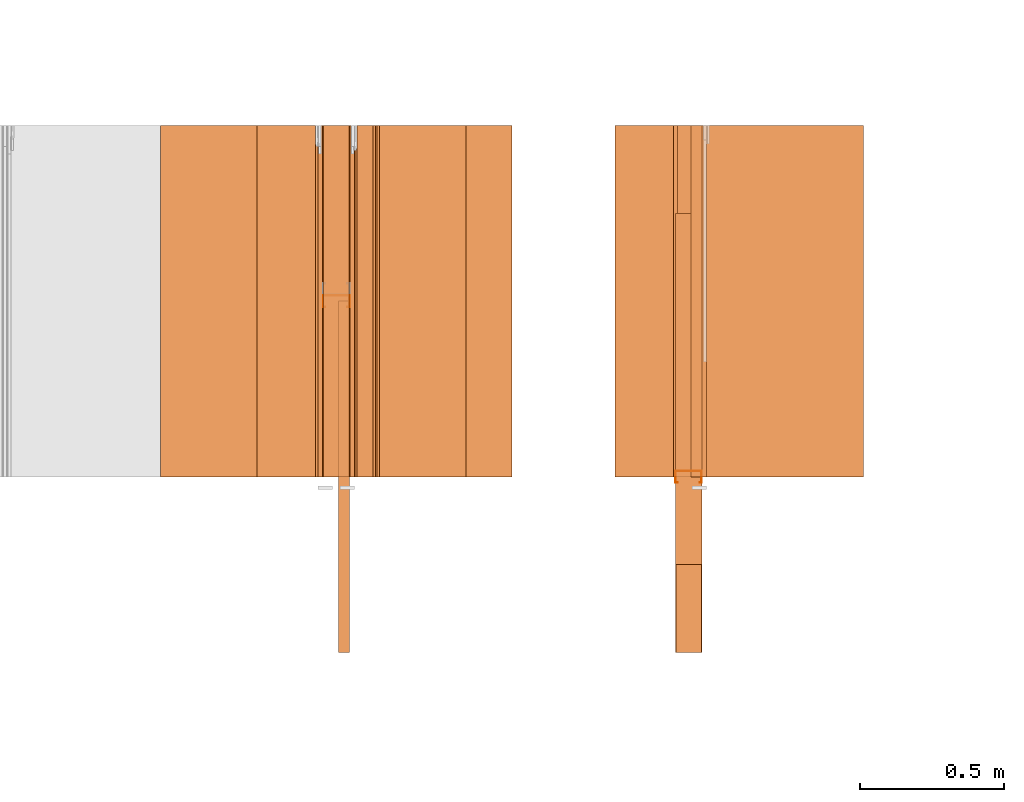
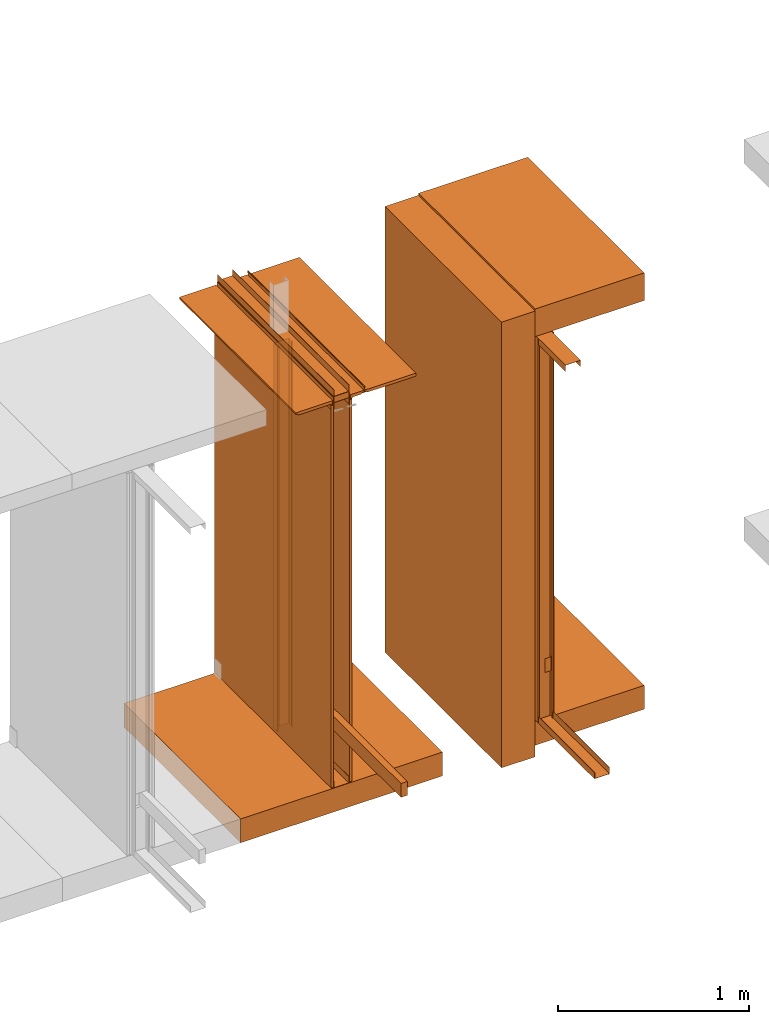
# One storey, part 38 of 64: 26 proxies.
"""IFC4 building model written with IfcOpenShell, lengths in feet."""

from ifc_helpers import new_model, entity, si_unit, converted_unit, frame, origin_with_axes, origin_2d_with_axis, place, context, subcontext, project, spatial, polyline, line, indexed_curve, outline, extrude, material, element, save


model = new_model("IFC4")

# Units and contexts
model_context_1 = context("Model", 3, precision=1e-05, world=origin_with_axes())
plan_context = context("Plan", 2, precision=1e-05, world=origin_2d_with_axis())
model_context_2 = context("Model", 3, precision=1e-05, world=origin_with_axes())
context_of_model_1 = context(None, 3, precision=1e-05, world=origin_with_axes())
context_of_model_2 = context(None, 3, precision=1e-05, world=origin_with_axes())
body_context = subcontext(model_context_2, "Body", "Model", "MODEL_VIEW")
ifc_project = project(units=[converted_unit("PLANEANGLEUNIT", "degree", entity("IfcReal", 0.0174532925199433), si_unit("PLANEANGLEUNIT", "RADIAN"), dimensions=[0, 0, 0, 0, 0, 0, 0]), converted_unit("AREAUNIT", "square foot", entity("IfcReal", 0.09290304), si_unit("AREAUNIT", "SQUARE_METRE"), dimensions=[2, 0, 0, 0, 0, 0, 0]), converted_unit("LENGTHUNIT", "foot", entity("IfcReal", 0.3048), si_unit("LENGTHUNIT", "METRE"), dimensions=[1, 0, 0, 0, 0, 0, 0]), converted_unit("VOLUMEUNIT", "cubic foot", entity("IfcReal", 0.0283168467116885), si_unit("VOLUMEUNIT", "CUBIC_METRE"), dimensions=[3, 0, 0, 0, 0, 0, 0])], contexts=[model_context_1, plan_context, context_of_model_1, context_of_model_2])

# Site, building, storey
site_placement = place(None, origin_with_axes())
site = spatial("IfcSite", under=ifc_project, at=site_placement)
building_placement = place(site_placement, origin_with_axes())
building = spatial("IfcBuilding", under=site, at=building_placement, Name="Building")
storey_placement = place(building_placement, origin_with_axes())
storey = spatial("IfcBuildingStorey", under=building, at=storey_placement, Name="Storey")

# Proxies
proxy_1_placement = place(storey_placement, frame((1406.35412821932, 5.99999987860051, -0.741135700559366), z_axis=(4.37113882867379e-08, -0.999999999999999, -8.51092183247426e-15), x_axis=(1.94707183709394e-07, 0.0, 0.999999999999981)))
element("IfcBuildingElementProxy", 1, at=proxy_1_placement, inside=storey, Name="Generic Models 502:Generic Models 1", PredefinedType="COMPLEX", context=body_context, shape_type="SweptSolid", body=[
    extrude(outline(polyline([(-0.333333353749097, -4.66965471352805), (0.333333353749097, -4.66965471352805), (0.333333353749097, 4.66965471352805), (-0.333333353749097, 4.66965471352805), (-0.333333353749097, -4.66965471352805)])), frame((4.66965471352805, -0.333332449315101, -4.3084304278221e-07), z_axis=(-3.30130176396781e-14, 1.19209268234499e-07, -1.0), x_axis=(-1.94707169498542e-07, 1.0, 1.19209268234499e-07)), (-4.20686507851542e-09, -1.62255897606656e-08, -1.0), 4.00000000752362),
])
ifc_material_1 = material()
proxy_2_placement = place(storey_placement, frame((1407.04167483673, 4.00000004943587, 0.0), z_axis=(4.37113882867379e-08, -0.999999999999999, -8.51092183247426e-15), x_axis=(1.94707183709394e-07, 0.0, 0.999999999999981)))
element("IfcBuildingElementProxy", 2, at=proxy_2_placement, inside=storey, material=ifc_material_1, Name="Generic Models 551:Generic Models 1", PredefinedType="COMPLEX", context=body_context, shape_type="SweptSolid", body=[
    extrude(outline(polyline([(-0.0664062512026528, -0.151041638487437), (0.0690104100080769, -0.151041638487437), (0.0690104161191174, 0.151041662931599), (-0.0664062450916122, 0.151041662931599), (-0.0664062450916122, 0.145833333098669), (0.0638020801751476, 0.145833333098669), (0.0638020801751476, -0.14583334532075), (-0.0664062512026528, -0.14583334532075), (-0.0664062512026528, -0.151041638487437)])), frame((0.0690104405632795, -0.151041650709518, -1.80055693306445e-08), z_axis=(9.13299180748707e-14, 1.19209062177106e-07, -1.0), x_axis=(-1.0, -1.80510738800876e-07, 0.0)), (7.05140945633786e-10, -1.49934752113889e-11, -1.0), 4.00000000752362),
])
ifc_material_2 = material(Category="steel")
proxy_3_placement = place(storey_placement, frame((1403.03123654343, 5.99999987860051, 7.94263493044796), z_axis=(4.37113882867379e-08, -0.999999999999999, -8.51092183247426e-15), x_axis=(1.94707183709394e-07, 0.0, 0.999999999999981)))
element("IfcBuildingElementProxy", 3, at=proxy_3_placement, inside=storey, material=ifc_material_2, Name="Generic Models 559:Generic Models 1", PredefinedType="COMPLEX", context=body_context, shape_type="SweptSolid", body=[
    extrude(outline(polyline([(-0.0690104161191174, -0.151041626265356), (0.0664062450916122, -0.151041626265356), (0.0664062450916122, -0.145833333098669), (-0.0638020862861881, -0.145833333098669), (-0.0638020801751476, 0.14583334532075), (0.0664062512026528, 0.14583334532075), (0.0664062512026528, 0.15104167515368), (-0.0690104100080769, 0.15104167515368), (-0.0690104161191174, -0.151041626265356)])), frame((0.0664062756468148, -0.151041662931599, -1.800557078763e-08), z_axis=(-2.09778510751671e-13, 1.192093463942e-07, -1.0), x_axis=(-1.0, -1.80510738800876e-07, 0.0)), (7.05141722789904e-10, 1.02818017988504e-10, -1.0), 4.00000000752362),
])
ifc_material_3 = material(Category="steel")
proxy_4_placement = place(storey_placement, frame((1407.04167483673, 5.00000015957149, 7.92708296788333), z_axis=(4.37113882867379e-08, -0.999999999999999, -8.51092183247426e-15), x_axis=(1.94707183709394e-07, 0.0, 0.999999999999981)))
element("IfcBuildingElementProxy", 4, at=proxy_4_placement, inside=storey, material=ifc_material_3, Name="Generic Models 564:Generic Models 1", PredefinedType="COMPLEX", context=body_context, shape_type="SweptSolid", body=[
    extrude(outline(polyline([(-0.0690104161191174, -0.151041626265356), (0.0664062450916122, -0.151041626265356), (0.0664062450916122, -0.145833333098669), (-0.0638020862861881, -0.145833333098669), (-0.0638020801751476, 0.14583334532075), (0.0664062512026528, 0.14583334532075), (0.0664062512026528, 0.15104167515368), (-0.0690104100080769, 0.15104167515368), (-0.0690104161191174, -0.151041626265356)])), frame((0.0664062756468148, -0.151041662931599, -1.800557078763e-08), z_axis=(-2.09778510751671e-13, 1.192093463942e-07, -1.0), x_axis=(-1.0, -1.80510738800876e-07, 0.0)), (7.05141722789904e-10, 1.02818017988504e-10, -1.0), 4.00000000752362),
])
ifc_material_4 = material(Category="sand")
proxy_5_placement = place(storey_placement, frame((1407.34374679605, 5.99999987860051, 0.0208333330815585), z_axis=(4.37113882867379e-08, -0.999999999999999, -8.51092183247426e-15), x_axis=(1.94707183709394e-07, 0.0, 0.999999999999981)))
element("IfcBuildingElementProxy", 5, at=proxy_5_placement, inside=storey, material=ifc_material_4, Name="Generic Models 600:Generic Models 1", PredefinedType="COMPLEX", context=body_context, shape_type="SweptSolid", body=[
    extrude(outline(polyline([(-4.00000004943587, -0.0260416674977682), (4.00000004943587, -0.0260416674977682), (4.00000004943587, 0.0260416674977682), (-4.00000004943587, 0.0260416674977682), (-4.00000004943587, -0.0260416674977682)])), frame((4.00000004943587, -0.0260408883401024, -3.94211021364806e-07), z_axis=(-2.90393285860922e-14, 1.19209140336807e-07, -1.0), x_axis=(1.0, 1.94707183709397e-07, -5.82794243094743e-15)), (-1.26761612317949e-09, -1.26070057171468e-10, -1.0), 4.00000000752362),
])
ifc_material_5 = material(Name="2X WOOD TOP PLATE", Category="wood1")
proxy_6_placement = place(storey_placement, frame((1407.21879293287, 5.99999987860051, 0.955116717521287), z_axis=(4.37113882867379e-08, -0.999999999999999, -8.51092183247426e-15), x_axis=(1.94707183709394e-07, 0.0, 0.999999999999981)))
element("IfcBuildingElementProxy", 6, at=proxy_6_placement, inside=storey, material=ifc_material_5, Name="Generic Models 602:Generic Models 1", PredefinedType="COMPLEX", context=body_context, shape_type="SweptSolid", body=[
    extrude(outline(polyline([(-0.145833320876588, -0.0625000007724355), (0.14583334532075, -0.0625000007724355), (0.14583334532075, 0.062499994661395), (-0.145833320876588, 0.0625000007724355), (-0.145833320876588, -0.0625000007724355)])), frame((0.145833333098669, -0.0624999702172329, -3.98557174431872e-07), z_axis=(-2.66321880049375e-14, 1.19209289550781e-07, -1.0), x_axis=(1.0, 1.94707197920252e-07, 0.0)), (1.31984683598985e-11, -5.84090220634437e-10, -1.0), 4.00000000752362),
])
ifc_material_6 = material(Category="InsulationBatt")
proxy_7_placement = place(storey_placement, frame((1407.06770689156, 5.99999987860051, 0.0226435821694065), z_axis=(4.37113882867379e-08, -0.999999999999999, -8.51092183247426e-15), x_axis=(1.94707183709394e-07, 0.0, 0.999999999999981)))
element("IfcBuildingElementProxy", 7, at=proxy_7_placement, inside=storey, material=ifc_material_6, Name="Generic Models 604:Generic Models 1", PredefinedType="COMPLEX", context=body_context, shape_type="SweptSolid", body=[
    extrude(outline(polyline([(-2.54716440605053, -0.16276041422225), (5.48488003375336, -0.16276041422225), (5.48487964264677, 0.0872395888674916), (-1.32302462741772, 0.0872395827564511), (-1.32302462741772, -0.0117187696237733), (-1.61469129361506, -0.0117187650404929), (-1.61469129361506, 0.0872396010895727), (-2.54716440605053, 0.0872395888674916), (-2.54716440605053, -0.16276041422225)])), frame((2.54716440605053, -0.162759913116928, -4.10509165301612e-07), z_axis=(-2.67290834919057e-14, 1.19209289550781e-07, -1.0), x_axis=(1.0, 1.94707183709397e-07, -5.8046913765453e-15)), (-7.92265986149232e-09, -1.33251243372712e-09, -1.0), 4.00000000752362),
])
proxy_8_placement = place(storey_placement, frame((1403.03123654343, 5.99999987860051, 8.2030516909802), z_axis=(4.37113882867379e-08, -0.999999999999999, -8.51092183247426e-15), x_axis=(1.94707183709394e-07, 0.0, 0.999999999999981)))
element("IfcBuildingElementProxy", 8, at=proxy_8_placement, inside=storey, material=ifc_material_3, Name="Generic Models 609:Generic Models 1", PredefinedType="COMPLEX", context=body_context, shape_type="SweptSolid", body=[
    extrude(outline(polyline([(-0.0690104161191174, -0.151041662931599), (0.0664062450916122, -0.151041662931599), (0.0664062450916122, -0.145833333098669), (-0.0638020801751476, -0.145833333098669), (-0.0638020801751476, 0.14583334532075), (0.0664062512026528, 0.14583334532075), (0.0664062450916122, 0.151041638487437), (-0.0690104161191174, 0.151041638487437), (-0.0690104161191174, -0.151041662931599)])), frame((0.06901044667432, -0.151041650709518, -1.80055693306445e-08), z_axis=(1.39309882531656e-13, 1.19209154547661e-07, -1.0), x_axis=(1.0, 1.94707169498542e-07, -8.51092183247427e-15)), (2.86545592809162e-10, 3.3153459977342e-09, -1.0), 4.00000000752362),
])
proxy_9_placement = place(storey_placement, frame((1403.03123654343, 5.99999987860051, 0.0), z_axis=(4.37113882867379e-08, -0.999999999999999, -8.51092183247426e-15), x_axis=(1.94707183709394e-07, 0.0, 0.999999999999981)))
element("IfcBuildingElementProxy", 9, at=proxy_9_placement, inside=storey, material=ifc_material_1, Name="Generic Models 403:Generic Models 1", PredefinedType="COMPLEX", context=body_context, shape_type="SweptSolid", body=[
    extrude(outline(polyline([(-0.151041638487437, -0.069010422230158), (0.151041662931599, -0.069010422230158), (0.151041662931599, 0.0664062389805717), (0.145833333098669, 0.0664062389805717), (0.145833333098669, -0.0638020862861881), (-0.14583334532075, -0.0638020862861881), (-0.14583334532075, 0.0664062450916122), (-0.151041638487437, 0.0664062389805717), (-0.151041638487437, -0.069010422230158)])), frame((0.0690104527853605, -0.151041650709518, -1.80055693306445e-08), z_axis=(2.93181657336911e-13, 1.19208870330567e-07, -1.0), x_axis=(-1.94707169498542e-07, 0.999999940395355, 1.19209147442234e-07)), (-2.59826077320113e-10, 2.86868306886845e-10, -1.0), 4.00000000752362),
])
ifc_material_7 = material(Name="UNDERSIDE OF FLOOR ASSEMBLY", Category="sand")
proxy_10_placement = place(storey_placement, frame((1407.02084919286, 5.99999987860051, 8.06249971464863), z_axis=(4.37113882867379e-08, -0.999999999999999, -8.51092183247426e-15), x_axis=(1.94707183709394e-07, 0.0, 0.999999999999981)))
element("IfcBuildingElementProxy", 10, at=proxy_10_placement, inside=storey, material=ifc_material_7, Name="Generic Models 420:Generic Models 1", PredefinedType="COMPLEX", context=body_context, shape_type="SweptSolid", body=[
    extrude(outline(polyline([(-0.288976855048044, -1.0807292042129), (0.288976903936369, -1.0807292042129), (0.288976928380531, 1.08072910643625), (-0.288976855048044, 1.0807292042129), (-0.288976855048044, -1.0807292042129)])), frame((0.288977075045503, -1.08072910643625, -5.19939553645375e-07), z_axis=(-4.59178491941676e-14, 1.19209282445354e-07, -1.0), x_axis=(1.0, 1.94707183709397e-07, 0.0)), (2.39291231274308e-09, -7.36614191865215e-09, -1.0), 4.00000000752362),
])
ifc_material_8 = material(Name="STRUCTURAL FLOOR", Category="concrete")
proxy_11_placement = place(storey_placement, frame((1407.02084919286, 5.99999987860051, -0.500000006179484), z_axis=(4.37113882867379e-08, -0.999999999999999, -8.51092183247426e-15), x_axis=(1.94707183709394e-07, 0.0, 0.999999999999981)))
element("IfcBuildingElementProxy", 11, at=proxy_11_placement, inside=storey, material=ifc_material_8, Name="Generic Models 453:Generic Models 1", PredefinedType="COMPLEX", context=body_context, shape_type="SweptSolid", body=[
    extrude(outline(polyline([(-0.250000003089742, -1.0807292042129), (0.250000003089742, -1.0807292042129), (0.250000027533904, 1.08072930198955), (-0.250000003089742, 1.0807292042129), (-0.250000003089742, -1.0807292042129)])), frame((0.250000223087201, -1.0807292042129, -5.19939553645375e-07), z_axis=(0.0, 1.19209289550781e-07, -1.0), x_axis=(1.0, 1.94707183709397e-07, 0.0)), (2.39290653958335e-09, 1.5180740220444e-08, -1.0), 4.00000000752362),
])
ifc_material_9 = material(Category="wood1")
proxy_12_placement = place(storey_placement, frame((1403.03123654343, 5.99999987860051, 8.07805167721325), z_axis=(4.37113882867379e-08, -0.999999999999999, -8.51092183247426e-15), x_axis=(1.94707183709394e-07, 0.0, 0.999999999999981)))
element("IfcBuildingElementProxy", 12, at=proxy_12_placement, inside=storey, material=ifc_material_9, Name="Generic Models 578:Generic Models 1", PredefinedType="COMPLEX", context=body_context, shape_type="SweptSolid", body=[
    extrude(outline(polyline([(-0.0625000007724355, -0.151041638487437), (0.0625000007724355, -0.151041638487437), (0.0625000007724355, 0.151041662931599), (-0.0625000007724355, 0.151041662931599), (-0.0625000007724355, -0.151041638487437)])), frame((0.0625000313276381, -0.151041650709518, -1.80055678736589e-08), z_axis=(-1.58239036023716e-14, 1.19209289550781e-07, -1.0), x_axis=(-1.0, -1.9555329799914e-07, 0.0)), (-2.54603865768033e-10, 4.3999508897441e-11, -1.0), 4.00000000752362),
])
ifc_material_10 = material()
proxy_13_placement = place(storey_placement, frame((1403.03123654343, 3.93229167605322, 0.00520833327038962), z_axis=(0.0, 0.0, 1.0), x_axis=(1.0, 0.0, 0.0)))
element("IfcBuildingElementProxy", 13, at=proxy_13_placement, inside=storey, material=ifc_material_10, Name="Generic Models 581:Generic Models 65", PredefinedType="COMPLEX", context=body_context, shape_type="SweptSolid", body=[
    extrude(outline(polyline([(-0.0842013872983887, 0.145833333098669), (0.040798611190962, 0.145833333098669), (0.040798611190962, 0.12499998932279), (0.0460069440794116, 0.12499998932279), (0.0460069440794116, 0.151041662931599), (-0.0894097171313181, 0.151041662931599), (-0.0894097171313181, -0.151041638487437), (0.0460069440794116, -0.151041638487437), (0.0460069440794116, -0.125000001544871), (0.040798611190962, -0.125000001544871), (0.040798611190962, -0.14583334532075), (-0.0842013872983887, -0.14583334532075), (-0.0842013872983887, 0.145833333098669)])), frame((0.151041662931599, 0.0460069440794116, 0.0), z_axis=(0.0, 0.0, -1.0), x_axis=(0.0, -1.0, 0.0)), (0.0, 0.0, -1.0), 8.0676348771059),
])
proxy_14_placement = place(storey_placement, frame((1403.33701306441, 5.99999987860051, 0.0208333330815585), z_axis=(4.37113882867379e-08, -0.999999999999999, -8.51092183247426e-15), x_axis=(1.94707183709394e-07, 0.0, 0.999999999999981)))
element("IfcBuildingElementProxy", 14, at=proxy_14_placement, inside=storey, material=ifc_material_4, Name="Generic Models 583:Generic Models 1", PredefinedType="COMPLEX", context=body_context, shape_type="SweptSolid", body=[
    extrude(outline(indexed_curve([(-4.00429713757332, -0.0260416705532884), (4.00429713757332, -0.0260416705532884), (4.00429713757332, 0.0260416644422479), (-4.00429713757332, 0.0260416644422479)], segments=[line(3, 2), line(2, 1), line(1, 4), line(4, 3)], self_intersect=False)), frame((4.00429713757332, -0.0260408852845821, -3.94211021364806e-07), z_axis=(-2.90081645498968e-14, 1.19209147442234e-07, -1.0), x_axis=(-1.0, -1.94580380252773e-07, 5.82168836318138e-15)), (1.26679033929378e-09, 4.38494379695342e-11, -1.0), 4.00000000752362),
])
proxy_15_placement = place(storey_placement, frame((1402.97546787212, 5.99999987860051, 0.0208333330815585), z_axis=(4.37113882867379e-08, -0.999999999999999, -8.51092183247426e-15), x_axis=(1.94707183709394e-07, 0.0, 0.999999999999981)))
element("IfcBuildingElementProxy", 15, at=proxy_15_placement, inside=storey, material=ifc_material_4, Name="Generic Models 584:Generic Models 1", PredefinedType="COMPLEX", context=body_context, shape_type="SweptSolid", body=[
    extrude(outline(polyline([(-0.0260424466554339, -4.00429713757332), (0.0260408883401024, -4.00429713757332), (0.0260424466554339, 4.00429713757332), (-0.0260408883401024, 4.00429713757332), (-0.0260424466554339, -4.00429713757332)])), frame((4.00429713757332, -0.0260408883401024, -3.10444292028814e-09), z_axis=(-3.17388734109685e-14, 1.19209289550781e-07, -1.0), x_axis=(0.0, 1.0, 1.19209289550781e-07)), (4.40009660651608e-11, -3.16894371800349e-14, -1.0), 4.00000000752362),
])
proxy_16_placement = place(storey_placement, frame((1403.20835463957, 0.0, 0.955116717521287), z_axis=(0.0, 0.0, 1.0), x_axis=(-1.62920684942944e-07, 0.999999999999987, 0.0)))
element("IfcBuildingElementProxy", 16, at=proxy_16_placement, inside=storey, material=ifc_material_5, Name="Generic Models 585:Generic Models 1", PredefinedType="COMPLEX", context=body_context, shape_type="SweptSolid", body=[
    extrude(outline(polyline([(-2.00000002471794, -0.0625000007724355), (2.00000002471794, -0.0625000007724355), (2.00000002471794, 0.0625000007724355), (-2.00000002471794, 0.0625000007724355), (-2.00000002471794, -0.0625000007724355)])), frame((2.00000002471794, -0.0625000007724355, 0.0), z_axis=(0.0, 0.0, -1.0), x_axis=(1.0, 0.0, 0.0)), (0.0, 0.0, -1.0), 0.291666664589754),
])
proxy_17_placement = place(storey_placement, frame((1401.18225978741, 5.99999987860051, -0.500000006179484), z_axis=(4.37113882867379e-08, -0.999999999999999, -8.51092183247426e-15), x_axis=(1.94707183709394e-07, 0.0, 0.999999999999981)))
element("IfcBuildingElementProxy", 17, at=proxy_17_placement, inside=storey, material=ifc_material_8, Name="Generic Models 596:Generic Models 1", PredefinedType="COMPLEX", context=body_context, shape_type="SweptSolid", body=[
    extrude(outline(polyline([(-0.250000394196335, -2.00000002471794), (0.249999611983149, -2.00000002471794), (0.250000394196335, 2.00000002471794), (-0.249999611983149, 2.00000002471794), (-0.250000394196335, -2.00000002471794)])), frame((0.250000394196335, -2.00000002471794, -6.29525198374314e-07), z_axis=(0.0, 1.19209289550781e-07, -1.0), x_axis=(-1.0, 0.0, 0.0)), (0.0, 2.1432619234929e-08, -1.0), 4.00000000752362),
])
proxy_18_placement = place(storey_placement, frame((1407.04167483673, 5.93229150521787, 0.00520833327038962), z_axis=(0.0, -0.999999999999999, -4.37113882867379e-08), x_axis=(1.0, 0.0, 0.0)))
element("IfcBuildingElementProxy", 18, at=proxy_18_placement, inside=storey, material=ifc_material_10, Name="Generic Models 597:Generic Models 65", PredefinedType="COMPLEX", context=body_context, shape_type="SweptSolid", body=[
    extrude(outline(polyline([(-0.089409704909237, -0.15104167515368), (0.0460070418560599, -0.15104167515368), (0.0460070418560599, -0.125000013766952), (0.0407986753568875, -0.125000013766952), (0.0407986753568875, -0.14583334532075), (-0.0842013384100646, -0.14583334532075), (-0.0842013384100646, 0.145833333098669), (0.0407986753568875, 0.145833333098669), (0.0407986753568875, 0.12499998932279), (0.0460070418560599, 0.12499998932279), (0.0460070418560599, 0.151041626265356), (-0.089409704909237, 0.151041626265356), (-0.089409704909237, -0.15104167515368)])), frame((0.15104167515368, 8.05208141722391, 3.95399222536663), z_axis=(0.0, 1.0, 0.0), x_axis=(0.0, 0.0, 1.0)), (4.85721010079487e-08, 0.0, -1.0), 8.05208291955147),
])
ifc_material_11 = material(Name="EXISTING ACOUSTICAL TILE", Category="poche")
proxy_19_placement = place(storey_placement, frame((1403.64469192785, 5.99999987860051, 8.06249971464863), z_axis=(4.37113882867379e-08, -0.999999999999999, -8.51092183247426e-15), x_axis=(1.94707183709394e-07, 0.0, 0.999999999999981)))
element("IfcBuildingElementProxy", 19, at=proxy_19_placement, inside=storey, material=ifc_material_11, Name="Generic Models 612:Generic Models 1", PredefinedType="COMPLEX", context=body_context, shape_type="SweptSolid", body=[
    extrude(outline(polyline([(-0.0329862356068581, -0.659830506470573), (0.0295137621100571, -0.659830506470573), (0.0295139515523131, 0.301973107136454), (0.00347228405454497, 0.311451502085671), (0.00347229322110574, 0.353118165193267), (-0.0329860400535616, 0.353118165193267), (-0.0329862356068581, -0.659830506470573)])), frame((0.0295139607188739, -0.353118165193267, -4.33201587754251e-07), z_axis=(4.87306592647507e-13, 1.19209303761636e-07, -1.0), x_axis=(-1.0, 0.0, 0.0)), (0.0, -3.01151925619081e-09, -1.0), 4.00000000752362),
])
ifc_material_12 = material(Name="J BEAD DRYWALL TRIM", Category="poche")
proxy_20_placement = place(storey_placement, frame((1402.97186343376, 5.99999987860051, 7.94737514235529), z_axis=(4.37113882867379e-08, -0.999999999999999, -8.51092183247426e-15), x_axis=(1.94707183709394e-07, 0.0, 0.999999999999981)))
element("IfcBuildingElementProxy", 20, at=proxy_20_placement, inside=storey, material=ifc_material_12, Name="Generic Models 613:Generic Models 1", PredefinedType="COMPLEX", context=body_context, shape_type="SweptSolid", body=[
    extrude(outline(polyline([(-0.0243062542120772, 0.0260416674977682), (0.0594405694485806, 0.0260416674977682), (0.0594405694485806, 0.0297083345845615), (-0.0275154549168946, 0.0297083345845615), (-0.029642769230867, 8.63165892654935e-10), (-0.0275154549168946, -0.0297083345845615), (0.0202739024608154, -0.0297083376400818), (0.0201072345250665, -0.0260416705532884), (-0.0243062557398373, -0.0260416644422479), (-0.0259760960330331, -1.47329117774072e-09), (-0.0243062542120772, 0.0260416674977682)])), frame((0.0594405755596211, -0.0297083223624805, -3.54150982380888e-09), z_axis=(-6.85859856863931e-14, 1.19209275339927e-07, -1.0), x_axis=(-1.0, -1.96107990291239e-07, 8.69875138852791e-15)), (-7.12182327000654e-11, 1.85316553769077e-10, -1.0), 4.00000000752362),
])
proxy_21_placement = place(storey_placement, frame((1403.33330850276, 5.99999987860051, 7.94737514235529), z_axis=(4.37113882867379e-08, -0.999999999999999, -8.51092183247426e-15), x_axis=(1.94707183709394e-07, 0.0, 0.999999999999981)))
element("IfcBuildingElementProxy", 21, at=proxy_21_placement, inside=storey, material=ifc_material_12, Name="Generic Models 614:Generic Models 1", PredefinedType="COMPLEX", context=body_context, shape_type="SweptSolid", body=[
    extrude(outline(indexed_curve([(-0.0202739024608154, -0.0297083345845615), (0.0275154549168946, -0.0297083345845615), (0.029642769230867, -9.87907171495233e-10), (0.0275154549168946, 0.0297083345845615), (-0.0594405694485806, 0.0297083345845615), (-0.0594405694485806, 0.0260416674977682), (0.0243062557398373, 0.0260416644422479), (0.0259760960330331, 1.35368577312851e-09), (0.0243062542120772, -0.0260416674977682), (-0.0201072360528266, -0.0260416674977682)], segments=[line(3, 2), line(2, 1), line(1, 10), line(10, 9), line(9, 8), line(8, 7), line(7, 6), line(6, 5), line(5, 4), line(4, 3)], self_intersect=False)), frame((0.0594405755596211, -0.0297083223624805, -3.94648117043793e-07), z_axis=(-1.54196956852343e-12, 1.19208372950652e-07, -1.0), x_axis=(0.999999940395355, 1.94707169498542e-07, 0.0)), (8.16310768980699e-11, -2.05222977500696e-10, -1.0), 4.00000000752362),
])
proxy_22_placement = place(storey_placement, frame((1402.27700781634, 5.99999987860051, 8.06249971464863), z_axis=(4.37113882867379e-08, -0.999999999999999, -8.51092183247426e-15), x_axis=(1.94707183709394e-07, 0.0, 0.999999999999981)))
element("IfcBuildingElementProxy", 22, at=proxy_22_placement, inside=storey, material=ifc_material_11, Name="Generic Models 615:Generic Models 1", PredefinedType="COMPLEX", context=body_context, shape_type="SweptSolid", body=[
    extrude(outline(polyline([(0.210121185995462, 2.22077733135034e-09), (0.215847768730379, 0.0271148456558781), (0.257101349943266, 0.032967398324468), (0.25198037132347, 0.0690642910523052), (-0.471914592846798, -0.0336330739678595), (-0.463135765371673, -0.0955134549537512), (0.210121185995462, 2.22077733135034e-09)])), frame((0.0295139423857524, -0.259183112561233, -4.22003639382244e-07), z_axis=(0.0, 1.19209261129072e-07, -1.0), x_axis=(-0.140461504459381, 0.990086138248444, 1.18027550399802e-07)), (4.49586146089587e-09, -8.24930679321767e-10, -1.0), 4.00000000752362),
])
ifc_material_13 = material(Name="CEILING TRACK AS SCHEDULED", Category="poche")
proxy_23_placement = place(storey_placement, frame((1403.33330850276, 5.99999987860051, 8.05729173925605), z_axis=(4.37113882867379e-08, -0.999999999999999, -8.51092183247426e-15), x_axis=(1.94707183709394e-07, 0.0, 0.999999999999981)))
element("IfcBuildingElementProxy", 23, at=proxy_23_placement, inside=storey, material=ifc_material_13, Name="Generic Models 616:Generic Models 1", PredefinedType="COMPLEX", context=body_context, shape_type="SweptSolid", body=[
    extrude(outline(indexed_curve([(0.0867708292826423, 1.32269660010439e-10), (0.0849992875254217, 0.00489779348971611), (-0.0276499528076079, -0.0358476722735198), (-0.0542230852769585, 0.0376192231973012), (-0.0591208825860749, 0.0358476783845603), (-0.0307762053039834, -0.0425170082843366)], segments=[line(1, 6), line(6, 5), line(5, 4), line(4, 3), line(3, 2), line(2, 1)], self_intersect=False)), frame((0.0434027852739875, -0.0295138812753472, -3.94624898521325e-07), z_axis=(0.0, 1.19209815352406e-07, -1.0), x_axis=(0.940376162528992, 0.340136259794235, 4.0547099899868e-08)), (-1.29517271907353e-10, -1.93627558431331e-10, -1.0), 4.00000000752362),
])
proxy_24_placement = place(storey_placement, frame((1403.35643698224, 5.99999987860051, 8.06249971464863), z_axis=(4.37113882867379e-08, -0.999999999999999, -8.51092183247426e-15), x_axis=(1.94707183709394e-07, 0.0, 0.999999999999981)))
element("IfcBuildingElementProxy", 24, at=proxy_24_placement, inside=storey, material=ifc_material_11, Name="Generic Models 617:Generic Models 1", PredefinedType="COMPLEX", context=body_context, shape_type="SweptSolid", body=[
    extrude(outline(indexed_curve([(0.0648317110585415, 7.63877378164006e-10), (0.056761629840364, 0.0265119365096249), (-0.164585280919012, 0.0383837601986379), (-0.167932627805731, -0.0240265442488661), (0.104485947413864, -0.0386375669888624), (0.106438559301569, -0.00223155644309177)], segments=[line(3, 2), line(2, 1), line(1, 6), line(6, 5), line(5, 4), line(4, 3)], self_intersect=False)), frame((0.0295139240526308, -0.166404782122201, -4.1094360343887e-07), z_axis=(-6.03470832333253e-13, 1.19209332183345e-07, -1.0), x_axis=(-0.0535573028028011, -0.998564839363098, -1.19038290335993e-07)), (2.012843003385e-09, 2.74091055407766e-10, -1.0), 4.00000000752362),
])
proxy_25_placement = place(storey_placement, frame((1402.94793396797, 5.99999987860051, 8.05729173925605), z_axis=(4.37113882867379e-08, -0.999999999999999, -8.51092183247426e-15), x_axis=(1.94707183709394e-07, 0.0, 0.999999999999981)))
element("IfcBuildingElementProxy", 25, at=proxy_25_placement, inside=storey, material=ifc_material_13, Name="Generic Models 618:Generic Models 1", PredefinedType="COMPLEX", context=body_context, shape_type="SweptSolid", body=[
    extrude(outline(polyline([(0.0691399640670129, 3.0555206221712e-09), (0.065870422948142, 0.00405423806092929), (0.00505689710312648, -0.044988927228518), (-0.0701426147065294, 0.0482584744584294), (-0.0741968500938785, 0.044988927228518), (0.00427220589016855, -0.0523127006792177), (0.0691399640670129, 3.0555206221712e-09)])), frame((0.0434027883295077, -0.0538194388288056, -6.41577852378924e-09), z_axis=(4.3276988505943e-15, 1.19209282445354e-07, -1.0), x_axis=(-0.627752602100372, 0.778412938117981, 9.27940746464628e-08)), (3.64590246881846e-10, -2.63130697786274e-11, -1.0), 4.00000000752362),
])
proxy_26_placement = place(storey_placement, frame((1403.59763398258, 6.00000339855985, 8.07805402385281), z_axis=(4.37113882867379e-08, -0.999999999999999, -8.51092183247426e-15), x_axis=(1.94707183709394e-07, 0.0, 0.999999999999981)))
element("IfcBuildingElementProxy", 26, at=proxy_26_placement, inside=storey, Name="Generic Models 565:Generic Models 1", PredefinedType="COMPLEX", context=body_context, shape_type="SweptSolid", body=[
    extrude(outline(indexed_curve([(0.0296970291596072, 0.00584526601665485), (0.0310626083843195, 0.00603154810081942), (0.0626632511087759, 0.0014601720208571), (0.0643079704421712, 0.000482393316240135), (0.0647795777719008, -0.00137198206741275), (0.0625126995146275, -0.0170422039603389), (0.0615349085879295, -0.0186869355158152), (0.0596805194544354, -0.0191585306234638), (0.0280798858965397, -0.0145871407936603), (0.0268230801374893, -0.0140215089945538), (0.0260570398201858, -0.0128758294517639), (0.0234390624243952, -0.00470634757631563), (-0.0547061508076554, 0.00659821266577313), (-0.0569313823238132, 0.00603231159894387), (-0.0581047204359779, 0.00405863991980086), (-0.0618188275302958, -0.0216159434852207), (-0.0612498224368246, -0.0282138154604851), (-0.063385453876939, -0.0304752946134627), (-0.0653873390843236, -0.0280945523937778), (-0.0547449498038905, 0.0454730346916229), (-0.052150489219765, 0.0471888804255821), (-0.0507432907536196, 0.0444148408048578), (-0.0531587436834345, 0.0382487337029199), (-0.0568728507777524, 0.0125741541172986), (-0.0563069378707822, 0.0103488813516173), (-0.0543332734484998, 0.00917554858661308), (0.0238125019992782, -0.00212908727960206), (0.0286377505631506, 0.00496365217335542), (0.0301359515891379, 0.00484996925051913), (0.0636623756779148, 1.22221276552383e-08), (0.0610525213827298, -0.0180413728345215), (0.0275254770233406, -0.0131913027518338), (0.024430948466043, -0.0035348496512263)], segments=[line(7, 6), line(6, 5), line(5, 4), line(4, 3), line(3, 2), line(2, 1), line(1, 28), line(28, 27), line(27, 26), line(26, 25), line(25, 24), line(24, 23), line(23, 22), line(22, 21), line(21, 20), line(20, 19), line(19, 18), line(18, 17), line(17, 16), line(16, 15), line(15, 14), line(14, 13), line(13, 12), line(12, 11), line(11, 10), line(10, 9), line(9, 8), line(8, 7)], self_intersect=False), holes=[indexed_curve([(0.0296970291596072, 0.00584526601665485), (0.0310626083843195, 0.00603154810081942), (0.0626632511087759, 0.0014601720208571), (0.0643079704421712, 0.000482393316240135), (0.0647795777719008, -0.00137198206741275), (0.0625126995146275, -0.0170422039603389), (0.0615349085879295, -0.0186869355158152), (0.0596805194544354, -0.0191585306234638), (0.0280798858965397, -0.0145871407936603), (0.0268230801374893, -0.0140215089945538), (0.0260570398201858, -0.0128758294517639), (0.0234390624243952, -0.00470634757631563), (-0.0547061508076554, 0.00659821266577313), (-0.0569313823238132, 0.00603231159894387), (-0.0581047204359779, 0.00405863991980086), (-0.0618188275302958, -0.0216159434852207), (-0.0612498224368246, -0.0282138154604851), (-0.063385453876939, -0.0304752946134627), (-0.0653873390843236, -0.0280945523937778), (-0.0547449498038905, 0.0454730346916229), (-0.052150489219765, 0.0471888804255821), (-0.0507432907536196, 0.0444148408048578), (-0.0531587436834345, 0.0382487337029199), (-0.0568728507777524, 0.0125741541172986), (-0.0563069378707822, 0.0103488813516173), (-0.0543332734484998, 0.00917554858661308), (0.0238125019992782, -0.00212908727960206), (0.0286377505631506, 0.00496365217335542), (0.0301359515891379, 0.00484996925051913), (0.0636623756779148, 1.22221276552383e-08), (0.0610525213827298, -0.0180413728345215), (0.0275254770233406, -0.0131913027518338), (0.024430948466043, -0.0035348496512263)], segments=[line(31, 32), line(32, 33), line(33, 29), line(29, 30), line(30, 31)], self_intersect=False)]), frame((0.0606913649992836, -0.0392497557501389, -3.95785544903478e-07), z_axis=(4.56824942457468e-12, 1.19214490723607e-07, -1.0), x_axis=(0.989697992801666, -0.143170446157455, -1.70668190691003e-08)), (-5.47911105375221e-10, -1.58496715751966e-10, -1.0), 4.00000000752362),
])

save(model, "model.ifc")
